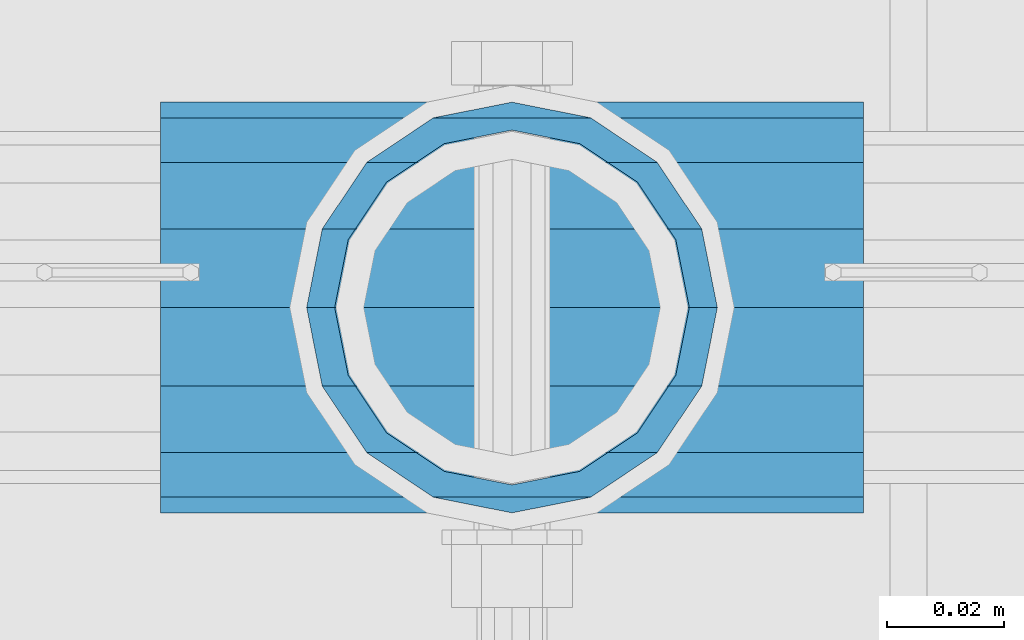
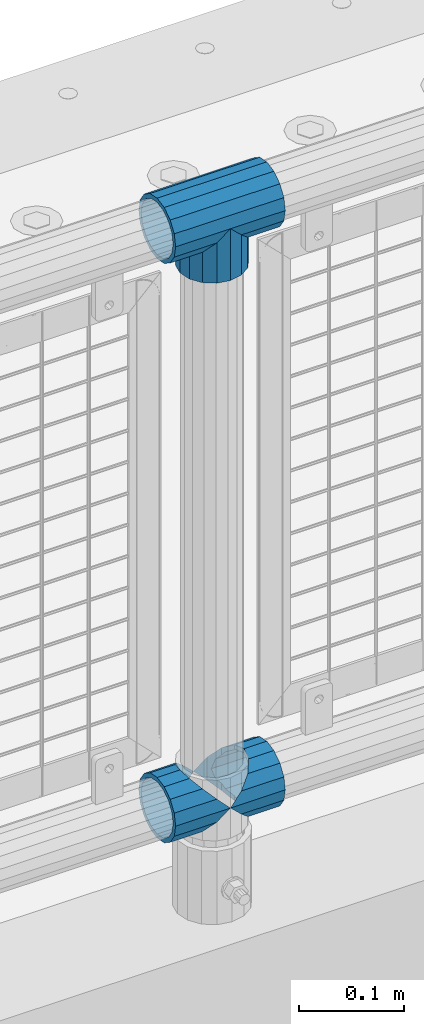
# One storey, part 111 of 193: 4 beams.
"""IFC2X3 building model written with IfcOpenShell, lengths in millimetres."""

from ifc_helpers import new_model, si_unit, frame, origin_with_axes, place, context, subcontext, project, spatial, faceted_brep, material, type_object, element, save


model = new_model("IFC2X3")

# Units and contexts
model_context = context("Model", 3, precision=1e-05, world=origin_with_axes())
body_context = subcontext(model_context, "Body", "Model", "MODEL_VIEW")
ifc_project = project(units=[si_unit("LENGTHUNIT", "METRE", prefix="MILLI"), si_unit("AREAUNIT", "SQUARE_METRE"), si_unit("VOLUMEUNIT", "CUBIC_METRE"), si_unit("MASSUNIT", "GRAM", prefix="KILO"), si_unit("TIMEUNIT", "SECOND"), si_unit("PLANEANGLEUNIT", "RADIAN"), si_unit("SOLIDANGLEUNIT", "STERADIAN"), si_unit("THERMODYNAMICTEMPERATUREUNIT", "DEGREE_CELSIUS"), si_unit("LUMINOUSINTENSITYUNIT", "LUMEN")], contexts=[model_context])

# Site, building, storey
site_placement = place(None, origin_with_axes())
site = spatial("IfcSite", under=ifc_project, at=site_placement, CompositionType="ELEMENT")
building_placement = place(site_placement, origin_with_axes())
building = spatial("IfcBuilding", under=site, at=building_placement, Name="Standard", CompositionType="ELEMENT")
storey_placement = place(building_placement, origin_with_axes())
storey = spatial("IfcBuildingStorey", under=building, at=storey_placement, Name="Undefined", CompositionType="ELEMENT", Elevation=0.0)

# Beams
ifc_material = material(Name="Misc_Undefined")
beam_type = type_object("IfcBeamType", PredefinedType="NOTDEFINED")
beam_1_placement = place(storey_placement, frame((-40231.15, 28664.5, 298.17), z_axis=(0.0, 1.0, 0.0), x_axis=(1.0, 0.0, 0.0)))
element("IfcBeam", 1, at=beam_1_placement, inside=storey, type_object=beam_type, material=ifc_material, context=body_context, shape_type="Brep", body=[
    faceted_brep([(60.1500000000015, 0.0, -35.1500000000015), (46.6986773523677, 13.4513226476329, -32.4743655677703), (46.6986773523677, -13.4513226476329, -32.4743655677703), (33.0273231408864, 21.4606908090117, 21.46069080901), (27.6756344322312, 26.8123795176734, 13.4513226476338), (27.6756344322312, 32.4743655677717, 13.4513226476338), (35.2951966412948, 24.8548033587072, 24.8548033587067), (35.2951966412948, 16.3810424080078, 24.8548033587067), (27.3102561882843, 28.0397438117175, 11.614442172282), (25.0, 30.35, 0.0), (25.0, 35.15, 0.0), (27.6756344322312, 26.8123795176755, -13.4513226476338), (27.6756344322312, 32.4743655677717, -13.4513226476338), (27.3102561882843, 28.0397438117175, -11.614442172282), (35.2951966412948, 16.3810424080013, -24.8548033587067), (35.2951966412948, 24.8548033587072, -24.8548033587067), (33.0273231408974, 21.4606908090117, -21.46069080901), (40.0617968770202, 11.6144421722805, -28.0397438117179), (43.519339601633, 0.0, -30.3499999999985), (40.0617968770202, -11.6144421722805, -28.0397438117179), (35.2951966412948, -16.3810424080013, -24.8548033587067), (35.2951966412948, -24.8548033587072, -24.8548033587067), (33.0273231408974, -21.4606908090117, -21.46069080901), (27.6756344322312, -26.8123795176734, -13.4513226476338), (27.6756344322312, -32.4743655677717, -13.4513226476338), (27.3102561882843, -28.0397438117175, -11.614442172282), (25.0, -30.35, 0.0), (25.0, -35.15, 0.0), (27.3102561882843, -28.0397438117175, 11.614442172282), (27.6756344322312, -26.8123795176755, 13.4513226476338), (27.6756344322312, -32.4743655677717, 13.4513226476338), (33.0273231408864, -21.4606908090117, 21.46069080901), (35.2951966412948, -16.3810424080013, 24.8548033587067), (35.2951966412948, -24.8548033587072, 24.8548033587067), (60.1500000000015, 0.0, 35.1500000000015), (46.6986773523677, -13.4513226476329, 32.4743655677703), (46.6986773523677, 13.4513226476329, 32.4743655677703), (40.0617968770275, -11.6144421722805, 28.0397438117179), (43.5193396016439, 0.0, 30.3499999999985), (40.0617968770275, 11.6144421722805, 28.0397438117179), (0.0, -32.4743655677703, -13.4513226476338), (0.0, -24.8548033587067, -24.8548033587067), (0.0, -13.4513226476338, -32.4743655677703), (0.0, 0.0, -35.1500000000015), (0.0, 13.4513226476338, -32.4743655677703), (0.0, 24.8548033587067, -24.8548033587067), (0.0, 32.4743655677703, -13.4513226476338), (0.0, 35.1500000000015, 0.0), (0.0, 32.4743655677703, 13.4513226476338), (0.0, 24.8548033587067, 24.8548033587067), (0.0, 13.4513226476338, 32.4743655677703), (0.0, 0.0, 35.1500000000015), (0.0, -32.4743655677703, 13.4513226476338), (0.0, -35.1500000000015, 0.0), (0.0, -24.8548033587067, 24.8548033587067), (0.0, -13.4513226476338, 32.4743655677703), (0.0, -28.0397438117179, -11.614442172282), (0.0, -21.46069080901, -21.46069080901), (0.0, -11.614442172282, -28.0397438117179), (0.0, 0.0, -30.3499999999985), (0.0, 11.614442172282, -28.0397438117179), (0.0, 21.46069080901, -21.46069080901), (0.0, 28.0397438117179, -11.614442172282), (0.0, 30.3499999999985, 0.0), (0.0, 28.0397438117179, 11.614442172282), (0.0, 21.46069080901, 21.46069080901), (0.0, 11.614442172282, 28.0397438117179), (0.0, 0.0, 30.3499999999985), (0.0, -11.614442172282, 28.0397438117179), (0.0, -21.46069080901, 21.46069080901), (0.0, -28.0397438117179, 11.614442172282), (0.0, -30.3499999999985, 0.0)], [[[0, 1, 2]], [[3, 4, 5, 6, 7]], [[8, 9, 10, 5, 4]], [[11, 12, 10, 9, 13]], [[14, 15, 12, 11, 16]], [[2, 1, 15, 14, 17, 18, 19, 20, 21]], [[21, 20, 22, 23, 24]], [[24, 23, 25, 26, 27]], [[27, 26, 28, 29, 30]], [[30, 29, 31, 32, 33]], [[34, 35, 36]], [[33, 32, 37, 38, 39, 7, 6, 36, 35]], [[40, 41, 21, 24]], [[41, 42, 2, 21]], [[42, 43, 0, 2]], [[43, 44, 1, 0]], [[44, 45, 15, 1]], [[45, 46, 12, 15]], [[46, 47, 10, 12]], [[47, 48, 5, 10]], [[48, 49, 6, 5]], [[49, 50, 36, 6]], [[50, 51, 34, 36]], [[52, 53, 27, 30]], [[54, 52, 30, 33]], [[55, 54, 33, 35]], [[51, 55, 35, 34]], [[53, 40, 24, 27]], [[52, 54, 55, 51, 50, 49, 48, 47, 46, 45, 44, 43, 42, 41, 40, 53], [56, 57, 58, 59, 60, 61, 62, 63, 64, 65, 66, 67, 68, 69, 70, 71]], [[68, 67, 38, 37]], [[31, 69, 68, 37, 32]], [[28, 70, 69, 31, 29]], [[71, 70, 28, 26]], [[56, 71, 26, 25]], [[57, 56, 25, 23, 22]], [[58, 57, 22, 20, 19]], [[59, 58, 19, 18]], [[60, 59, 18, 17]], [[16, 61, 60, 17, 14]], [[13, 62, 61, 16, 11]], [[63, 62, 13, 9]], [[64, 63, 9, 8]], [[65, 64, 8, 4, 3]], [[66, 65, 3, 7, 39]], [[67, 66, 39, 38]]]),
])
beam_2_placement = place(storey_placement, frame((-40171.0, 28664.5, 298.17), z_axis=(0.0, 1.0, 0.0), x_axis=(1.0, 0.0, 0.0)))
element("IfcBeam", 2, at=beam_2_placement, inside=storey, type_object=beam_type, material=ifc_material, context=body_context, shape_type="Brep", body=[
    faceted_brep([(0.0, 0.0, 35.1500000000015), (13.4513226476338, 13.4513226476329, 32.4743655677703), (13.4513226476338, -13.4513226476329, 32.4743655677703), (24.8548033587067, -16.3810424080013, -24.8548033587067), (24.8548033587067, -24.8548033587072, -24.8548033587067), (32.4743655677703, -32.4743655677717, -13.4513226476338), (32.4743655677703, -26.8123795176754, -13.4513226476338), (27.1226768591114, -21.4606908090117, -21.46069080901), (0.0, 0.0, -35.1500000000015), (13.4513226476338, -13.4513226476329, -32.4743655677703), (13.4513226476338, 13.4513226476329, -32.4743655677703), (20.0882031229849, -11.6144421722805, -28.0397438117179), (16.6306603983721, 0.0, -30.3499999999985), (20.0882031229849, 11.6144421722805, -28.0397438117179), (24.8548033587067, 16.3810424080013, -24.8548033587067), (24.8548033587067, 24.8548033587072, -24.8548033587067), (27.1226768591114, 21.4606908090117, -21.46069080901), (32.4743655677703, 26.8123795176776, -13.4513226476338), (32.4743655677703, 32.4743655677717, -13.4513226476338), (32.8397438117172, 28.0397438117175, -11.614442172282), (35.1500000000015, 30.35, 0.0), (35.1500000000015, 35.15, 0.0), (32.8397438117208, 28.0397438117175, 11.614442172282), (32.4743655677703, 26.8123795176754, 13.4513226476338), (32.4743655677703, 32.4743655677717, 13.4513226476338), (27.1226768591041, 21.4606908090117, 21.46069080901), (24.8548033587067, 16.3810424080078, 24.8548033587067), (24.8548033587067, 24.8548033587072, 24.8548033587067), (20.0882031229849, 11.6144421722805, 28.0397438117179), (16.6306603983685, 0.0, 30.3499999999985), (20.0882031229849, -11.6144421722805, 28.0397438117179), (24.8548033587067, -16.3810424080013, 24.8548033587067), (24.8548033587067, -24.8548033587072, 24.8548033587067), (27.1226768591041, -21.4606908090117, 21.46069080901), (32.4743655677703, -26.8123795176776, 13.4513226476338), (32.4743655677703, -32.4743655677717, 13.4513226476338), (32.8397438117208, -28.0397438117175, 11.614442172282), (35.1500000000015, -30.35, 0.0), (35.1500000000015, -35.15, 0.0), (32.8397438117172, -28.0397438117175, -11.614442172282), (60.1500000000015, -24.8548033587072, -24.8548033587067), (60.1500000000015, -32.4743655677717, -13.4513226476338), (60.1500000000015, -13.4513226476329, -32.4743655677703), (60.1500000000015, 0.0, -35.1500000000015), (60.1500000000015, 13.4513226476329, -32.4743655677703), (60.1500000000015, 24.8548033587072, -24.8548033587067), (60.1500000000015, 32.4743655677717, -13.4513226476338), (60.1500000000015, 35.15, 0.0), (60.1500000000015, 32.4743655677717, 13.4513226476338), (60.1500000000015, 24.8548033587072, 24.8548033587067), (60.1500000000015, 13.4513226476329, 32.4743655677703), (60.1500000000015, 0.0, 35.1500000000015), (60.1500000000015, -13.4513226476329, 32.4743655677703), (60.1500000000015, -24.8548033587072, 24.8548033587067), (60.1500000000015, -32.4743655677717, 13.4513226476338), (60.1500000000015, -35.15, 0.0), (60.1500000000015, -21.4606908090117, 21.46069080901), (60.1500000000015, -11.6144421722805, 28.0397438117179), (60.1500000000015, 0.0, 30.3499999999985), (60.1500000000015, 11.6144421722805, 28.0397438117179), (60.1500000000015, 21.4606908090117, 21.46069080901), (60.1500000000015, 28.0397438117175, 11.614442172282), (60.1500000000015, 30.35, 0.0), (60.1500000000015, 28.0397438117175, -11.614442172282), (60.1500000000015, 21.4606908090117, -21.46069080901), (60.1500000000015, 11.6144421722805, -28.0397438117179), (60.1500000000015, 0.0, -30.3499999999985), (60.1500000000015, -11.6144421722805, -28.0397438117179), (60.1500000000015, -21.4606908090117, -21.46069080901), (60.1500000000015, -28.0397438117175, -11.614442172282), (60.1500000000015, -30.35, 0.0), (60.1500000000015, -28.0397438117175, 11.614442172282)], [[[0, 1, 2]], [[3, 4, 5, 6, 7]], [[8, 9, 10]], [[10, 9, 4, 3, 11, 12, 13, 14, 15]], [[15, 14, 16, 17, 18]], [[18, 17, 19, 20, 21]], [[21, 20, 22, 23, 24]], [[24, 23, 25, 26, 27]], [[27, 26, 28, 29, 30, 31, 32, 2, 1]], [[33, 34, 35, 32, 31]], [[36, 37, 38, 35, 34]], [[6, 5, 38, 37, 39]], [[40, 41, 5, 4]], [[42, 40, 4, 9]], [[43, 42, 9, 8]], [[44, 43, 8, 10]], [[45, 44, 10, 15]], [[46, 45, 15, 18]], [[47, 46, 18, 21]], [[48, 47, 21, 24]], [[49, 48, 24, 27]], [[50, 49, 27, 1]], [[51, 50, 1, 0]], [[52, 51, 0, 2]], [[53, 52, 2, 32]], [[54, 53, 32, 35]], [[55, 54, 35, 38]], [[41, 55, 38, 5]], [[40, 42, 43, 44, 45, 46, 47, 48, 49, 50, 51, 52, 53, 54, 55, 41], [56, 57, 58, 59, 60, 61, 62, 63, 64, 65, 66, 67, 68, 69, 70, 71]], [[71, 70, 37, 36]], [[56, 71, 36, 34, 33]], [[57, 56, 33, 31, 30]], [[58, 57, 30, 29]], [[59, 58, 29, 28]], [[25, 60, 59, 28, 26]], [[22, 61, 60, 25, 23]], [[62, 61, 22, 20]], [[63, 62, 20, 19]], [[64, 63, 19, 17, 16]], [[65, 64, 16, 14, 13]], [[66, 65, 13, 12]], [[67, 66, 12, 11]], [[7, 68, 67, 11, 3]], [[39, 69, 68, 7, 6]], [[70, 69, 39, 37]]]),
])
beam_3_placement = place(storey_placement, frame((-40171.0, 28664.5, 969.849999999999), z_axis=(0.0, 1.0, 0.0), x_axis=(0.0, 0.0, -1.0)))
element("IfcBeam", 3, at=beam_3_placement, inside=storey, type_object=beam_type, material=ifc_material, context=body_context, shape_type="Brep", body=[
    faceted_brep([(0.0, 0.0, 35.1500000000015), (13.4513226476338, 13.4513226476329, 32.4743655677703), (13.4513226476338, -13.4513226476329, 32.4743655677703), (24.8548033587067, -16.3810424080013, -24.8548033587067), (24.8548033587067, -24.8548033587072, -24.8548033587067), (32.4743655677703, -32.4743655677717, -13.4513226476338), (32.4743655677703, -26.8123795176754, -13.4513226476338), (27.1226768591114, -21.4606908090117, -21.46069080901), (0.0, 0.0, -35.1500000000015), (13.4513226476338, -13.4513226476329, -32.4743655677703), (13.4513226476338, 13.4513226476329, -32.4743655677703), (20.0882031229849, -11.6144421722805, -28.0397438117179), (16.6306603983721, 0.0, -30.3499999999985), (20.0882031229849, 11.6144421722805, -28.0397438117179), (24.8548033587067, 16.3810424080013, -24.8548033587067), (24.8548033587067, 24.8548033587072, -24.8548033587067), (27.1226768591114, 21.4606908090117, -21.46069080901), (32.4743655677703, 26.8123795176776, -13.4513226476338), (32.4743655677703, 32.4743655677717, -13.4513226476338), (32.8397438117172, 28.0397438117175, -11.614442172282), (35.1500000000015, 30.35, 0.0), (35.1500000000015, 35.15, 0.0), (32.8397438117208, 28.0397438117175, 11.614442172282), (32.4743655677703, 26.8123795176754, 13.4513226476338), (32.4743655677703, 32.4743655677717, 13.4513226476338), (27.1226768591041, 21.4606908090117, 21.46069080901), (24.8548033587067, 16.3810424080078, 24.8548033587067), (24.8548033587067, 24.8548033587072, 24.8548033587067), (20.0882031229849, 11.6144421722805, 28.0397438117179), (16.6306603983685, 0.0, 30.3499999999985), (20.0882031229849, -11.6144421722805, 28.0397438117179), (24.8548033587067, -16.3810424080013, 24.8548033587067), (24.8548033587067, -24.8548033587072, 24.8548033587067), (27.1226768591041, -21.4606908090117, 21.46069080901), (32.4743655677703, -26.8123795176776, 13.4513226476338), (32.4743655677703, -32.4743655677717, 13.4513226476338), (32.8397438117208, -28.0397438117175, 11.614442172282), (35.1500000000015, -30.35, 0.0), (35.1500000000015, -35.15, 0.0), (32.8397438117172, -28.0397438117175, -11.614442172282), (60.1500000000015, -24.8548033587072, -24.8548033587067), (60.1500000000015, -32.4743655677717, -13.4513226476338), (60.1500000000015, -13.4513226476329, -32.4743655677703), (60.1500000000015, 0.0, -35.1500000000015), (60.1500000000015, 13.4513226476329, -32.4743655677703), (60.1500000000015, 24.8548033587072, -24.8548033587067), (60.1500000000015, 32.4743655677717, -13.4513226476338), (60.1500000000015, 35.15, 0.0), (60.1500000000015, 32.4743655677717, 13.4513226476338), (60.1500000000015, 24.8548033587072, 24.8548033587067), (60.1500000000015, 13.4513226476329, 32.4743655677703), (60.1500000000015, 0.0, 35.1500000000015), (60.1500000000015, -13.4513226476329, 32.4743655677703), (60.1500000000015, -24.8548033587072, 24.8548033587067), (60.1500000000015, -32.4743655677717, 13.4513226476338), (60.1500000000015, -35.15, 0.0), (60.1500000000015, -21.4606908090117, 21.46069080901), (60.1500000000015, -11.6144421722805, 28.0397438117179), (60.1500000000015, 0.0, 30.3499999999985), (60.1500000000015, 11.6144421722805, 28.0397438117179), (60.1500000000015, 21.4606908090117, 21.46069080901), (60.1500000000015, 28.0397438117175, 11.614442172282), (60.1500000000015, 30.35, 0.0), (60.1500000000015, 28.0397438117175, -11.614442172282), (60.1500000000015, 21.4606908090117, -21.46069080901), (60.1500000000015, 11.6144421722805, -28.0397438117179), (60.1500000000015, 0.0, -30.3499999999985), (60.1500000000015, -11.6144421722805, -28.0397438117179), (60.1500000000015, -21.4606908090117, -21.46069080901), (60.1500000000015, -28.0397438117175, -11.614442172282), (60.1500000000015, -30.35, 0.0), (60.1500000000015, -28.0397438117175, 11.614442172282)], [[[0, 1, 2]], [[3, 4, 5, 6, 7]], [[8, 9, 10]], [[10, 9, 4, 3, 11, 12, 13, 14, 15]], [[15, 14, 16, 17, 18]], [[18, 17, 19, 20, 21]], [[21, 20, 22, 23, 24]], [[24, 23, 25, 26, 27]], [[27, 26, 28, 29, 30, 31, 32, 2, 1]], [[33, 34, 35, 32, 31]], [[36, 37, 38, 35, 34]], [[6, 5, 38, 37, 39]], [[40, 41, 5, 4]], [[42, 40, 4, 9]], [[43, 42, 9, 8]], [[44, 43, 8, 10]], [[45, 44, 10, 15]], [[46, 45, 15, 18]], [[47, 46, 18, 21]], [[48, 47, 21, 24]], [[49, 48, 24, 27]], [[50, 49, 27, 1]], [[51, 50, 1, 0]], [[52, 51, 0, 2]], [[53, 52, 2, 32]], [[54, 53, 32, 35]], [[55, 54, 35, 38]], [[41, 55, 38, 5]], [[40, 42, 43, 44, 45, 46, 47, 48, 49, 50, 51, 52, 53, 54, 55, 41], [56, 57, 58, 59, 60, 61, 62, 63, 64, 65, 66, 67, 68, 69, 70, 71]], [[71, 70, 37, 36]], [[56, 71, 36, 34, 33]], [[57, 56, 33, 31, 30]], [[58, 57, 30, 29]], [[59, 58, 29, 28]], [[25, 60, 59, 28, 26]], [[22, 61, 60, 25, 23]], [[62, 61, 22, 20]], [[63, 62, 20, 19]], [[64, 63, 19, 17, 16]], [[65, 64, 16, 14, 13]], [[66, 65, 13, 12]], [[67, 66, 12, 11]], [[7, 68, 67, 11, 3]], [[39, 69, 68, 7, 6]], [[70, 69, 39, 37]]]),
])
beam_4_placement = place(storey_placement, frame((-40231.15, 28664.5, 969.849999999999), z_axis=(0.0, 0.0, 1.0), x_axis=(1.0, 0.0, 0.0)))
element("IfcBeam", 4, at=beam_4_placement, inside=storey, type_object=beam_type, material=ifc_material, context=body_context, shape_type="Brep", body=[
    faceted_brep([(88.1897438117194, -11.614442172282, -28.0397438117176), (88.1897438117194, -11.614442172282, -32.8397438117171), (86.9623795176703, -13.4513226476338, -32.4743655677718), (81.6106908090114, -21.46069080901, -27.1226768591079), (81.6106908090114, -21.46069080901, -21.4606908090117), (76.531042407998, -24.8548033587067, -24.8548033587072), (71.7644421722835, -28.0397438117179, -20.0882031229796), (71.7644421722835, -28.0397438117179, -11.6144421722805), (60.1500000000015, -30.3499999999985, -16.6306603983672), (60.1500000000015, -30.35, 0.0), (48.5355578277195, -28.0397438117179, -20.0882031229796), (48.5355578277195, -28.0397438117179, -11.6144421722805), (43.7689575919976, -24.8548033587067, -24.8548033587072), (38.6893091909915, -21.46069080901, -27.1226768591079), (38.6893091909915, -21.46069080901, -21.4606908090117), (33.3376204823326, -13.4513226476338, -32.4743655677718), (32.1102561882835, -11.614442172282, -32.8397438117171), (32.1102561882835, -11.614442172282, -28.0397438117176), (29.8000000000029, 0.0, -35.15), (29.8000000000029, 0.0, -30.35), (32.1102561882835, 11.614442172282, -32.8397438117171), (32.1102561882835, 11.614442172282, -28.0397438117176), (33.3376204823217, 13.4513226476338, -32.4743655677718), (38.6893091909915, 21.46069080901, -27.1226768591082), (38.6893091909915, 21.46069080901, -21.4606908090117), (43.7689575920012, 24.8548033587067, -24.8548033587072), (48.5355578277195, 28.0397438117179, -20.0882031229862), (48.5355578277195, 28.0397438117179, -11.6144421722805), (60.1500000000015, 30.3499999999985, -16.6306603983672), (60.1500000000015, 30.35, 0.0), (71.7644421722835, 28.0397438117179, -20.0882031229862), (71.7644421722835, 28.0397438117179, -11.6144421722805), (76.5310424080017, 24.8548033587067, -24.8548033587072), (81.6106908090114, 21.46069080901, -27.1226768591082), (81.6106908090114, 21.46069080901, -21.4606908090117), (86.962379517674, 13.4513226476338, -32.4743655677718), (88.1897438117194, 11.614442172282, -32.8397438117171), (88.1897438117194, 11.614442172282, -28.0397438117176), (90.5, 0.0, -35.15), (90.5, 0.0, -30.35), (0.0, -21.46069080901, -21.46069080901), (0.0, -28.0397438117179, -11.614442172282), (0.0, -11.614442172282, -28.0397438117179), (0.0, 0.0, -30.3499999999985), (0.0, 11.614442172282, -28.0397438117179), (0.0, 21.46069080901, -21.46069080901), (0.0, 28.0397438117179, -11.614442172282), (0.0, 30.3499999999985, 0.0), (0.0, 32.4743655677703, -13.4513226476338), (0.0, 35.1500000000015, 0.0), (120.299999999999, 35.1500000000015, 0.0), (120.299999999999, 32.4743655677703, -13.4513226476329), (0.0, 32.4743655677703, 13.4513226476338), (120.299999999999, 32.4743655677703, 13.4513226476329), (0.0, 24.8548033587067, 24.8548033587067), (120.299999999999, 24.8548033587067, 24.8548033587072), (0.0, 13.4513226476338, 32.4743655677703), (120.299999999999, 13.4513226476338, 32.4743655677718), (0.0, 0.0, 35.1500000000015), (120.299999999999, 0.0, 35.15), (0.0, -13.4513226476338, 32.4743655677703), (120.299999999999, -13.4513226476338, 32.4743655677718), (0.0, -24.8548033587067, 24.8548033587067), (120.299999999999, -24.8548033587067, 24.8548033587072), (0.0, -32.4743655677703, 13.4513226476338), (120.299999999999, -32.4743655677703, 13.4513226476329), (0.0, -35.1500000000015, 0.0), (120.299999999999, -35.1500000000015, 0.0), (0.0, -32.4743655677703, -13.4513226476338), (120.299999999999, -32.4743655677703, -13.4513226476329), (0.0, 24.8548033587067, -24.8548033587067), (0.0, 13.4513226476338, -32.4743655677703), (0.0, 0.0, -35.1500000000015), (0.0, -13.4513226476338, -32.4743655677703), (0.0, -24.8548033587067, -24.8548033587067), (0.0, 28.0397438117179, 11.614442172282), (0.0, 21.46069080901, 21.46069080901), (0.0, 11.614442172282, 28.0397438117179), (0.0, 0.0, 30.3499999999985), (0.0, -11.614442172282, 28.0397438117179), (0.0, -21.46069080901, 21.46069080901), (0.0, -28.0397438117179, 11.614442172282), (0.0, -30.3499999999985, 0.0), (120.299999999999, -30.3499999999985, 0.0), (120.299999999999, -28.0397438117179, -11.6144421722805), (120.299999999999, -21.46069080901, -21.4606908090117), (120.299999999999, -11.614442172282, -28.0397438117176), (120.299999999999, 0.0, -30.35), (120.299999999999, 21.46069080901, -21.4606908090117), (120.299999999999, 28.0397438117179, -11.6144421722805), (120.299999999999, 11.614442172282, -28.0397438117176), (120.299999999999, 30.3499999999985, 0.0), (120.299999999999, 28.0397438117179, 11.6144421722805), (120.299999999999, 21.46069080901, 21.4606908090117), (120.299999999999, 11.614442172282, 28.0397438117176), (120.299999999999, 0.0, 30.35), (120.299999999999, -11.614442172282, 28.0397438117176), (120.299999999999, -21.46069080901, 21.4606908090117), (120.299999999999, -28.0397438117179, 11.6144421722805), (120.299999999999, -24.8548033587067, -24.8548033587072), (120.299999999999, -13.4513226476338, -32.4743655677718), (120.299999999999, 0.0, -35.15), (120.299999999999, 13.4513226476338, -32.4743655677718), (120.299999999999, 24.8548033587067, -24.8548033587072)], [[[0, 1, 2, 3, 4]], [[4, 3, 5, 6, 7]], [[7, 6, 8, 9]], [[9, 8, 10, 11]], [[11, 10, 12, 13, 14]], [[14, 13, 15, 16, 17]], [[17, 16, 18, 19]], [[19, 18, 20, 21]], [[21, 20, 22, 23, 24]], [[24, 23, 25, 26, 27]], [[27, 26, 28, 29]], [[29, 28, 30, 31]], [[31, 30, 32, 33, 34]], [[34, 33, 35, 36, 37]], [[37, 36, 38, 39]], [[39, 38, 1, 0]], [[40, 41, 11, 14]], [[42, 40, 14, 17]], [[43, 42, 17, 19]], [[44, 43, 19, 21]], [[45, 44, 21, 24]], [[46, 45, 24, 27]], [[47, 46, 27, 29]], [[48, 49, 50, 51]], [[49, 52, 53, 50]], [[52, 54, 55, 53]], [[54, 56, 57, 55]], [[56, 58, 59, 57]], [[58, 60, 61, 59]], [[60, 62, 63, 61]], [[62, 64, 65, 63]], [[64, 66, 67, 65]], [[66, 68, 69, 67]], [[64, 62, 60, 58, 56, 54, 52, 49, 48, 70, 71, 72, 73, 74, 68, 66], [41, 40, 42, 43, 44, 45, 46, 47, 75, 76, 77, 78, 79, 80, 81, 82]], [[41, 82, 9, 11]], [[83, 84, 7, 9]], [[84, 85, 4, 7]], [[85, 86, 0, 4]], [[86, 87, 39, 0]], [[88, 89, 31, 34]], [[90, 88, 34, 37]], [[87, 90, 37, 39]], [[89, 91, 29, 31]], [[75, 47, 29, 91, 92]], [[76, 75, 92, 93]], [[77, 76, 93, 94]], [[78, 77, 94, 95]], [[79, 78, 95, 96]], [[80, 79, 96, 97]], [[81, 80, 97, 98]], [[9, 82, 81, 98, 83]], [[99, 100, 101, 102, 103, 51, 50, 53, 55, 57, 59, 61, 63, 65, 67, 69], [97, 96, 95, 94, 93, 92, 91, 89, 88, 90, 87, 86, 85, 84, 83, 98]], [[35, 102, 101, 38, 36]], [[32, 103, 102, 35, 33]], [[28, 26, 25, 70, 48, 51, 103, 32, 30]], [[22, 71, 70, 25, 23]], [[18, 72, 71, 22, 20]], [[73, 72, 18, 16, 15]], [[74, 73, 15, 13, 12]], [[99, 69, 68, 74, 12, 10, 8, 6, 5]], [[100, 99, 5, 3, 2]], [[101, 100, 2, 1, 38]]]),
])

save(model, "model.ifc")
